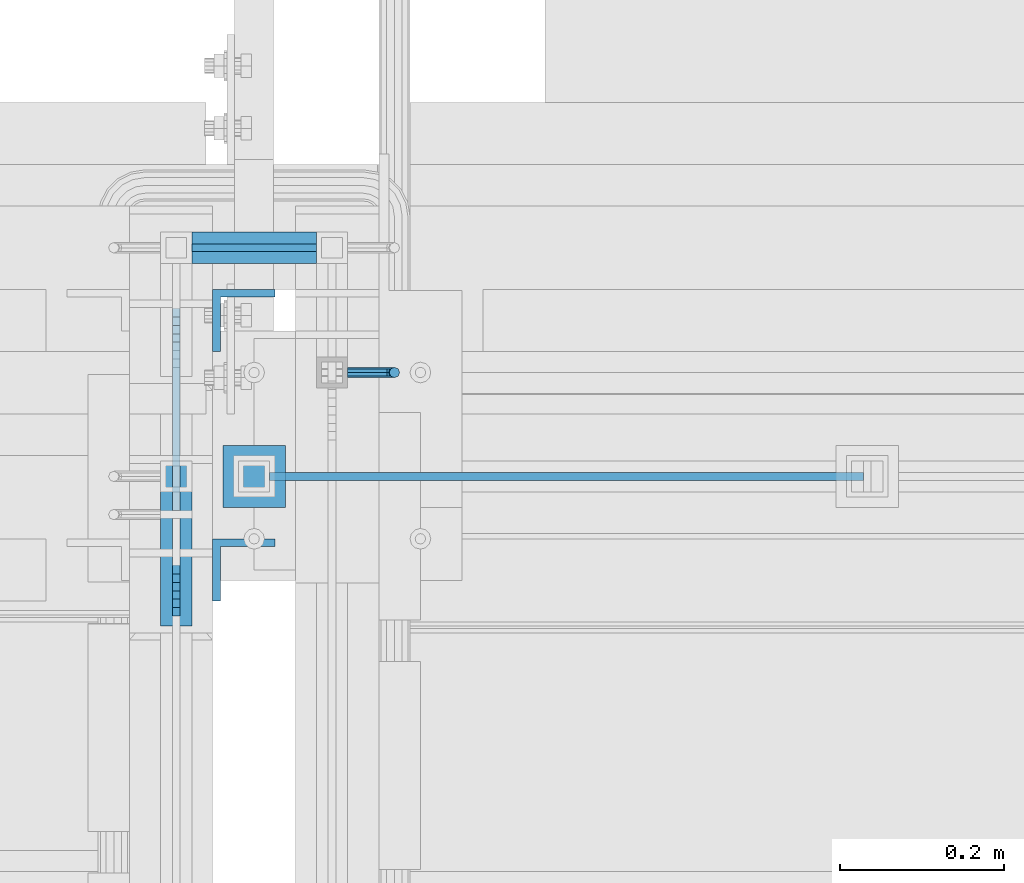
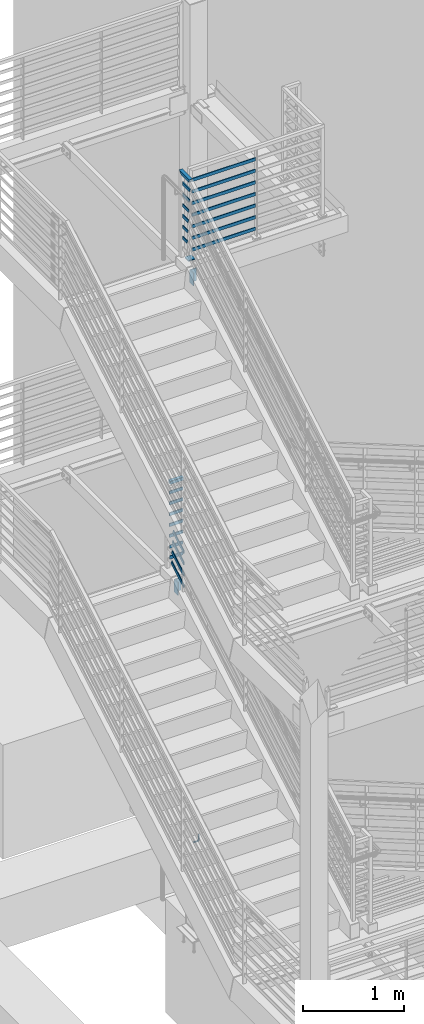
# One storey, part 864 of 1179: 26 beams, 4 members, 7 elements without a shape of their own.
"""IFC2X3 building model written with IfcOpenShell, lengths in millimetres."""

from ifc_helpers import new_model, si_unit, frame, origin_with_axes, place, context, subcontext, project, spatial, faceted_brep, material, type_object, element, aggregate, save


model = new_model("IFC2X3")

# Units and contexts
model_context = context("Model", 3, precision=1e-05, world=origin_with_axes())
body_context = subcontext(model_context, "Body", "Model", "MODEL_VIEW")
ifc_project = project(units=[si_unit("LENGTHUNIT", "METRE", prefix="MILLI"), si_unit("AREAUNIT", "SQUARE_METRE"), si_unit("VOLUMEUNIT", "CUBIC_METRE"), si_unit("MASSUNIT", "GRAM", prefix="KILO"), si_unit("TIMEUNIT", "SECOND"), si_unit("PLANEANGLEUNIT", "RADIAN"), si_unit("SOLIDANGLEUNIT", "STERADIAN"), si_unit("THERMODYNAMICTEMPERATUREUNIT", "DEGREE_CELSIUS"), si_unit("LUMINOUSINTENSITYUNIT", "LUMEN")], contexts=[model_context])

# Site, building, storey
site_placement = place(None, origin_with_axes())
site = spatial("IfcSite", under=ifc_project, at=site_placement, CompositionType="ELEMENT")
building_placement = place(site_placement, origin_with_axes())
building = spatial("IfcBuilding", under=site, at=building_placement, Name="Undefined", CompositionType="ELEMENT")
storey_placement = place(building_placement, origin_with_axes())
storey = spatial("IfcBuildingStorey", under=building, at=storey_placement, Name="Undefined", CompositionType="ELEMENT", Elevation=0.0)

# Assembly, beam
assembly_1_placement = place(storey_placement, origin_with_axes())
assembly_1 = element("IfcElementAssembly", 1, at=assembly_1_placement, inside=storey, Name="GUARDRAIL", AssemblyPlace="NOTDEFINED", PredefinedType="RIGID_FRAME")
ifc_material_1 = material(Name="STEEL/A36")
beam_type_1 = type_object("IfcBeamType", PredefinedType="NOTDEFINED")
beam_1_placement = place(assembly_1_placement, frame((-1638.3000007445, 35242.5000005577, 992.665205369077), z_axis=(0.0, 0.0, 1.0), x_axis=(1.0, 0.0, 0.0)))
beam_1 = element("IfcBeam", 2, at=beam_1_placement, type_object=beam_type_1, material=ifc_material_1, Name="BRACKET", context=body_context, shape_type="Brep", body=[
    faceted_brep([(0.0, -4.49012806053361, 4.49012806053452), (0.0, 0.0, 6.34999999999991), (0.0, 4.49012806053361, 4.49012806053452), (0.0, 6.34999999999854, 0.0), (0.0, 4.49012806053361, -4.49012806053452), (0.0, 0.0, -6.34999999999991), (0.0, -4.49012806053361, -4.49012806053452), (0.0, -6.34999999999854, 0.0), (44.4500031699827, 0.0, -6.34999999999991), (44.4500031699827, -4.49012806053361, -4.49012806053452), (44.4500031699827, -6.34999999999854, 2.19733919948339e-09), (44.4500031699827, -4.49012806053361, 4.49012806053452), (44.4500031699827, 0.0, 6.34999999999991), (44.4500031699827, 4.49012806053361, 4.49012806053452), (44.4500031699827, 6.34999999999854, 0.0), (44.4500031699827, 4.49012806053361, -4.49012806053452), (53.0450671075391, 4.4901280570557, -2.18708762112465), (53.97500307462, -4.32919478043914e-09, -3.79778396764459), (53.0450671022344, -4.49012806401151, -2.1870876194389), (50.8000030708674, -6.35000000142099, 1.70147734757802), (48.5549390416977, -4.4901280599006, 5.59004231389645), (47.6250030746168, 1.48793333210051e-09, 7.20073866041594), (48.5549390470023, 4.49012806117025, 5.5900423122107), (50.8000030783693, 6.34999999857973, 1.70147734519378), (55.4485256393576, 6.34999999469437, 6.34999990618098), (59.337090604122, 4.49012805180246, 4.10493587545716), (51.5599606707875, 4.49012805866005, 8.59506393599531), (49.9492643188311, -4.54747350886464e-10, 9.52499990463002), (51.5599606615996, -4.4901280624108, 8.59506393379797), (55.4485256263639, -6.35000000530636, 6.34999990307369), (59.337090594938, -4.49012806926839, 4.10493587326664), (60.9477869468905, -1.0153598850593e-08, 3.17499990462466), (61.6401310450869, 4.49012804462109, 12.6999998130159), (63.5000029792477, -1.81098585017025e-08, 12.6999998092651), (57.1500029867496, 6.3499999893902, 12.6999998145698), (52.6598749240178, 4.49012805522943, 12.6999998130159), (50.8000029792477, -3.10683390125632e-09, 12.6999998092651), (52.6598749134085, -4.49012806583778, 12.6999998055144), (57.1500029739432, -6.35000001061053, 12.6999998039605), (61.6401310344776, -4.49012807644976, 12.6999998055144), (63.5000029792478, -6.94672053214163e-08, 76.1999999999989), (61.6401294941604, -4.49012902507093, 78.7998225171882), (57.150001417061, -6.35000092034534, 79.8767042410154), (52.6598733730912, -4.49012891187158, 78.7998224516436), (50.8000029792478, -5.78438630327582e-08, 76.1999999999989), (52.6598734875952, 4.4901272704119, 73.6001773671805), (57.1500015724957, 6.34999916438028, 72.5232956441077), (61.6401296086642, 4.49012715460412, 73.6001774342335)], [[[0, 1, 2, 3, 4, 5, 6, 7]], [[6, 5, 8, 9]], [[7, 6, 9, 10]], [[0, 7, 10, 11]], [[1, 0, 11, 12]], [[2, 1, 12, 13]], [[3, 2, 13, 14]], [[4, 3, 14, 15]], [[5, 4, 15, 8]], [[8, 15, 16, 17]], [[9, 8, 17, 18]], [[10, 9, 18, 19]], [[11, 10, 19, 20]], [[12, 11, 20, 21]], [[13, 12, 21, 22]], [[14, 13, 22, 23]], [[15, 14, 23, 16]], [[23, 24, 25, 16]], [[22, 26, 24, 23]], [[21, 27, 26, 22]], [[20, 28, 27, 21]], [[19, 29, 28, 20]], [[18, 30, 29, 19]], [[17, 31, 30, 18]], [[16, 25, 31, 17]], [[25, 32, 33, 31]], [[24, 34, 32, 25]], [[26, 35, 34, 24]], [[27, 36, 35, 26]], [[28, 37, 36, 27]], [[29, 38, 37, 28]], [[30, 39, 38, 29]], [[31, 33, 39, 30]], [[39, 33, 40, 41]], [[38, 39, 41, 42]], [[37, 38, 42, 43]], [[36, 37, 43, 44]], [[35, 36, 44, 45]], [[34, 35, 45, 46]], [[32, 34, 46, 47]], [[33, 32, 47, 40]], [[46, 45, 44, 43, 42, 41, 40, 47]]]),
])
aggregate(assembly_1, [beam_1])

# Assembly, beams
assembly_2_placement = place(storey_placement, origin_with_axes())
assembly_2 = element("IfcElementAssembly", 3, at=assembly_2_placement, inside=storey, Name="GUARDRAIL", AssemblyPlace="NOTDEFINED", PredefinedType="RIGID_FRAME")
beam_type_2 = type_object("IfcBeamType", PredefinedType="NOTDEFINED")
beam_2_placement = place(assembly_2_placement, frame((-1828.81829244754, 35394.8983081136, 4394.23598620215), z_axis=(0.0, 0.0, 1.0), x_axis=(0.999999999938439, 1.10960000217655e-05, 0.0)))
beam_2 = element("IfcBeam", 4, at=beam_2_placement, type_object=beam_type_2, material=ifc_material_1, Name="PLATE", context=body_context, shape_type="Brep", body=[
    faceted_brep([(0.0, 4.76250000000073, -19.05), (0.0, 4.76250000000073, 19.0499992370605), (152.399956117868, 4.76250000043365, 19.0500000000002), (152.399956117868, 4.76250000043365, -19.0500000000002), (0.0, -4.76250000000073, 19.0499992370605), (152.399956117868, -4.76249999959691, 19.0500000000002), (0.0, -4.76250000000073, -19.05), (152.399956117868, -4.76249999959691, -19.0500000000002)], [[[0, 1, 2, 3]], [[1, 4, 5, 2]], [[4, 6, 7, 5]], [[6, 0, 3, 7]], [[5, 7, 3, 2]], [[6, 4, 1, 0]]]),
])
beam_3_placement = place(assembly_2_placement, frame((-1828.79960226161, 35394.898308321, 4524.37497131281), z_axis=(0.0, 0.0, 1.0), x_axis=(0.999999999938439, 1.10960000217655e-05, 0.0)))
beam_3 = element("IfcBeam", 5, at=beam_3_placement, type_object=beam_type_2, material=ifc_material_1, Name="PLATE", context=body_context, shape_type="Brep", body=[
    faceted_brep([(0.0, 4.76250000000073, -19.05), (0.0, 4.76250000000073, 19.0499992370605), (152.399956117868, 4.76250000043365, 19.0500000000002), (152.399956117868, 4.76250000043365, -19.0500000000002), (0.0, -4.76250000000073, 19.0499992370605), (152.399956117868, -4.76249999959691, 19.0500000000002), (0.0, -4.76250000000073, -19.05), (152.399956117868, -4.76249999959691, -19.0500000000002)], [[[0, 1, 2, 3]], [[1, 4, 5, 2]], [[4, 6, 7, 5]], [[6, 0, 3, 7]], [[5, 7, 3, 2]], [[6, 4, 1, 0]]]),
])
beam_4_placement = place(assembly_2_placement, frame((-1828.79960226161, 35394.8983089721, 4654.54997114588), z_axis=(0.0, 0.0, 1.0), x_axis=(0.999999999938439, 1.10960000217655e-05, 0.0)))
beam_4 = element("IfcBeam", 6, at=beam_4_placement, type_object=beam_type_2, material=ifc_material_1, Name="PLATE", context=body_context, shape_type="Brep", body=[
    faceted_brep([(0.0, 4.76250000000073, -19.05), (0.0, 4.76250000000073, 19.0499992370605), (152.399956117868, 4.76250000043365, 19.0500000000002), (152.399956117868, 4.76250000043365, -19.0500000000002), (0.0, -4.76250000000073, 19.0499992370605), (152.399956117868, -4.76249999959691, 19.0500000000002), (0.0, -4.76250000000073, -19.05), (152.399956117868, -4.76249999959691, -19.0500000000002)], [[[0, 1, 2, 3]], [[1, 4, 5, 2]], [[4, 6, 7, 5]], [[6, 0, 3, 7]], [[5, 7, 3, 2]], [[6, 4, 1, 0]]]),
])
beam_5_placement = place(assembly_2_placement, frame((-1828.79960226161, 35394.8983089721, 4784.72497215902), z_axis=(0.0, 0.0, 1.0), x_axis=(0.999999999938439, 1.10960000217655e-05, 0.0)))
beam_5 = element("IfcBeam", 7, at=beam_5_placement, type_object=beam_type_2, material=ifc_material_1, Name="PLATE", context=body_context, shape_type="Brep", body=[
    faceted_brep([(0.0, 4.76250000000073, -19.05), (0.0, 4.76250000000073, 19.0499992370605), (152.399956117868, 4.76250000043365, 19.0500000000002), (152.399956117868, 4.76250000043365, -19.0500000000002), (0.0, -4.76250000000073, 19.0499992370605), (152.399956117868, -4.76249999959691, 19.0500000000002), (0.0, -4.76250000000073, -19.05), (152.399956117868, -4.76249999959691, -19.0500000000002)], [[[0, 1, 2, 3]], [[1, 4, 5, 2]], [[4, 6, 7, 5]], [[6, 0, 3, 7]], [[5, 7, 3, 2]], [[6, 4, 1, 0]]]),
])
beam_6_placement = place(assembly_2_placement, frame((-1828.79960226161, 35394.8983089721, 4914.89997215621), z_axis=(0.0, 0.0, 1.0), x_axis=(0.999999999938439, 1.10960000217655e-05, 0.0)))
beam_6 = element("IfcBeam", 8, at=beam_6_placement, type_object=beam_type_2, material=ifc_material_1, Name="PLATE", context=body_context, shape_type="Brep", body=[
    faceted_brep([(0.0, 4.76250000000073, -19.05), (0.0, 4.76250000000073, 19.0499992370605), (152.399956117868, 4.76250000043365, 19.0500000000002), (152.399956117868, 4.76250000043365, -19.0500000000002), (0.0, -4.76250000000073, 19.0499992370605), (152.399956117868, -4.76249999959691, 19.0500000000002), (0.0, -4.76250000000073, -19.05), (152.399956117868, -4.76249999959691, -19.0500000000002)], [[[0, 1, 2, 3]], [[1, 4, 5, 2]], [[4, 6, 7, 5]], [[6, 0, 3, 7]], [[5, 7, 3, 2]], [[6, 4, 1, 0]]]),
])
beam_7_placement = place(assembly_2_placement, frame((-1828.79960226161, 35394.8983089721, 5045.07497215967), z_axis=(0.0, 0.0, 1.0), x_axis=(0.999999999938439, 1.10960000217655e-05, 0.0)))
beam_7 = element("IfcBeam", 9, at=beam_7_placement, type_object=beam_type_2, material=ifc_material_1, Name="PLATE", context=body_context, shape_type="Brep", body=[
    faceted_brep([(0.0, 4.76250000000073, -19.05), (0.0, 4.76250000000073, 19.0499992370605), (152.399956117868, 4.76250000043365, 19.0500000000002), (152.399956117868, 4.76250000043365, -19.0500000000002), (0.0, -4.76250000000073, 19.0499992370605), (152.399956117868, -4.76249999959691, 19.0500000000002), (0.0, -4.76250000000073, -19.05), (152.399956117868, -4.76249999959691, -19.0500000000002)], [[[0, 1, 2, 3]], [[1, 4, 5, 2]], [[4, 6, 7, 5]], [[6, 0, 3, 7]], [[5, 7, 3, 2]], [[6, 4, 1, 0]]]),
])
beam_8_placement = place(assembly_2_placement, frame((-1828.79960226161, 35394.8983089721, 5175.24997216603), z_axis=(0.0, 0.0, 1.0), x_axis=(0.999999999938439, 1.10960000217655e-05, 0.0)))
beam_8 = element("IfcBeam", 10, at=beam_8_placement, type_object=beam_type_2, material=ifc_material_1, Name="PLATE", context=body_context, shape_type="Brep", body=[
    faceted_brep([(0.0, 4.76250000000073, -19.05), (0.0, 4.76250000000073, 19.0499992370605), (152.399956117868, 4.76250000043365, 19.0500000000002), (152.399956117868, 4.76250000043365, -19.0500000000002), (0.0, -4.76250000000073, 19.0499992370605), (152.399956117868, -4.76249999959691, 19.0500000000002), (0.0, -4.76250000000073, -19.05), (152.399956117868, -4.76249999959691, -19.0500000000002)], [[[0, 1, 2, 3]], [[1, 4, 5, 2]], [[4, 6, 7, 5]], [[6, 0, 3, 7]], [[5, 7, 3, 2]], [[6, 4, 1, 0]]]),
])

assembly_3_placement = place(storey_placement, origin_with_axes())
assembly_3 = element("IfcElementAssembly", 11, at=assembly_3_placement, inside=storey, Name="GUARDRAIL", AssemblyPlace="NOTDEFINED", PredefinedType="RIGID_FRAME")
beam_9_placement = place(assembly_3_placement, frame((-1752.60069628364, 35115.5, 8236.00291878738), z_axis=(7.31000000250787e-05, 0.0, 0.999999997328195), x_axis=(0.999999997328195, 0.0, -7.31000000250648e-05)))
beam_9 = element("IfcBeam", 12, at=beam_9_placement, type_object=beam_type_2, material=ifc_material_1, Name="PLATE", context=body_context, shape_type="Brep", body=[
    faceted_brep([(19.0520881245343, 4.76249999999709, -19.0499999999938), (19.0493030145258, 4.76249999999709, 19.0499999999938), (744.536803398841, 4.76249999999709, 19.0500000000065), (744.539588508849, 4.76249999999709, -19.0499999999811), (19.0493030145258, -4.76249999999709, 19.0499999999938), (744.536803398841, -4.76249999999709, 19.0500000000065), (19.0520881245343, -4.76249999999709, -19.0499999999938), (744.539588508849, -4.76249999999709, -19.0499999999811)], [[[0, 1, 2, 3]], [[1, 4, 5, 2]], [[4, 6, 7, 5]], [[6, 0, 3, 7]], [[5, 7, 3, 2]], [[6, 4, 1, 0]]]),
])
beam_10_placement = place(assembly_3_placement, frame((-1752.60069628364, 35115.5, 8375.70291878737), z_axis=(7.31000000250787e-05, 0.0, 0.999999997328195), x_axis=(0.999999997328195, 0.0, -7.31000000250648e-05)))
beam_10 = element("IfcBeam", 13, at=beam_10_placement, type_object=beam_type_2, material=ifc_material_1, Name="PLATE", context=body_context, shape_type="Brep", body=[
    faceted_brep([(19.0520881245343, 4.76249999999709, -19.0499999999938), (19.0493030145258, 4.76249999999709, 19.0499999999938), (744.536803398841, 4.76249999999709, 19.0500000000065), (744.539588508849, 4.76249999999709, -19.0499999999811), (19.0493030145258, -4.76249999999709, 19.0499999999938), (744.536803398841, -4.76249999999709, 19.0500000000065), (19.0520881245343, -4.76249999999709, -19.0499999999938), (744.539588508849, -4.76249999999709, -19.0499999999811)], [[[0, 1, 2, 3]], [[1, 4, 5, 2]], [[4, 6, 7, 5]], [[6, 0, 3, 7]], [[5, 7, 3, 2]], [[6, 4, 1, 0]]]),
])
beam_11_placement = place(assembly_3_placement, frame((-1752.60069628364, 35115.5, 8515.40291878737), z_axis=(7.31000000250787e-05, 0.0, 0.999999997328195), x_axis=(0.999999997328195, 0.0, -7.31000000250648e-05)))
beam_11 = element("IfcBeam", 14, at=beam_11_placement, type_object=beam_type_2, material=ifc_material_1, Name="PLATE", context=body_context, shape_type="Brep", body=[
    faceted_brep([(19.0520881245343, 4.76249999999709, -19.0499999999938), (19.0493030145258, 4.76249999999709, 19.0499999999938), (744.536803398841, 4.76249999999709, 19.0500000000065), (744.539588508849, 4.76249999999709, -19.0499999999811), (19.0493030145258, -4.76249999999709, 19.0499999999938), (744.536803398841, -4.76249999999709, 19.0500000000065), (19.0520881245343, -4.76249999999709, -19.0499999999938), (744.539588508849, -4.76249999999709, -19.0499999999811)], [[[0, 1, 2, 3]], [[1, 4, 5, 2]], [[4, 6, 7, 5]], [[6, 0, 3, 7]], [[5, 7, 3, 2]], [[6, 4, 1, 0]]]),
])
beam_12_placement = place(assembly_3_placement, frame((-1752.60069628364, 35115.5, 8655.10291878737), z_axis=(7.31000000250787e-05, 0.0, 0.999999997328195), x_axis=(0.999999997328195, 0.0, -7.31000000250648e-05)))
beam_12 = element("IfcBeam", 15, at=beam_12_placement, type_object=beam_type_2, material=ifc_material_1, Name="PLATE", context=body_context, shape_type="Brep", body=[
    faceted_brep([(19.0520881245343, 4.76249999999709, -19.0499999999938), (19.0493030145258, 4.76249999999709, 19.0499999999938), (744.536803398841, 4.76249999999709, 19.0500000000065), (744.539588508849, 4.76249999999709, -19.0499999999811), (19.0493030145258, -4.76249999999709, 19.0499999999938), (744.536803398841, -4.76249999999709, 19.0500000000065), (19.0520881245343, -4.76249999999709, -19.0499999999938), (744.539588508849, -4.76249999999709, -19.0499999999811)], [[[0, 1, 2, 3]], [[1, 4, 5, 2]], [[4, 6, 7, 5]], [[6, 0, 3, 7]], [[5, 7, 3, 2]], [[6, 4, 1, 0]]]),
])
beam_13_placement = place(assembly_3_placement, frame((-1752.60069628364, 35115.5, 8794.80291878737), z_axis=(7.31000000250787e-05, 0.0, 0.999999997328195), x_axis=(0.999999997328195, 0.0, -7.31000000250648e-05)))
beam_13 = element("IfcBeam", 16, at=beam_13_placement, type_object=beam_type_2, material=ifc_material_1, Name="PLATE", context=body_context, shape_type="Brep", body=[
    faceted_brep([(19.0520881245343, 4.76249999999709, -19.0499999999938), (19.0493030145258, 4.76249999999709, 19.0499999999938), (744.536803398841, 4.76249999999709, 19.0500000000065), (744.539588508849, 4.76249999999709, -19.0499999999811), (19.0493030145258, -4.76249999999709, 19.0499999999938), (744.536803398841, -4.76249999999709, 19.0500000000065), (19.0520881245343, -4.76249999999709, -19.0499999999938), (744.539588508849, -4.76249999999709, -19.0499999999811)], [[[0, 1, 2, 3]], [[1, 4, 5, 2]], [[4, 6, 7, 5]], [[6, 0, 3, 7]], [[5, 7, 3, 2]], [[6, 4, 1, 0]]]),
])
beam_14_placement = place(assembly_3_placement, frame((-1752.60069628364, 35115.5, 8934.50291878736), z_axis=(7.31000000250787e-05, 0.0, 0.999999997328195), x_axis=(0.999999997328195, 0.0, -7.31000000250648e-05)))
beam_14 = element("IfcBeam", 17, at=beam_14_placement, type_object=beam_type_2, material=ifc_material_1, Name="PLATE", context=body_context, shape_type="Brep", body=[
    faceted_brep([(19.0520881245343, 4.76249999999709, -19.0499999999938), (19.0493030145258, 4.76249999999709, 19.0499999999938), (744.536803398841, 4.76249999999709, 19.0500000000065), (744.539588508849, 4.76249999999709, -19.0499999999811), (19.0493030145258, -4.76249999999709, 19.0499999999938), (744.536803398841, -4.76249999999709, 19.0500000000065), (19.0520881245343, -4.76249999999709, -19.0499999999938), (744.539588508849, -4.76249999999709, -19.0499999999811)], [[[0, 1, 2, 3]], [[1, 4, 5, 2]], [[4, 6, 7, 5]], [[6, 0, 3, 7]], [[5, 7, 3, 2]], [[6, 4, 1, 0]]]),
])
beam_15_placement = place(assembly_3_placement, frame((-1752.60069628364, 35115.5, 9074.20291878736), z_axis=(7.31000000250787e-05, 0.0, 0.999999997328195), x_axis=(0.999999997328195, 0.0, -7.31000000250648e-05)))
beam_15 = element("IfcBeam", 18, at=beam_15_placement, type_object=beam_type_2, material=ifc_material_1, Name="PLATE", context=body_context, shape_type="Brep", body=[
    faceted_brep([(19.0520881245343, 4.76249999999709, -19.0499999999938), (19.0493030145258, 4.76249999999709, 19.0499999999938), (744.536803398841, 4.76249999999709, 19.0500000000065), (744.539588508849, 4.76249999999709, -19.0499999999811), (19.0493030145258, -4.76249999999709, 19.0499999999938), (744.536803398841, -4.76249999999709, 19.0500000000065), (19.0520881245343, -4.76249999999709, -19.0499999999938), (744.539588508849, -4.76249999999709, -19.0499999999811)], [[[0, 1, 2, 3]], [[1, 4, 5, 2]], [[4, 6, 7, 5]], [[6, 0, 3, 7]], [[5, 7, 3, 2]], [[6, 4, 1, 0]]]),
])
aggregate(assembly_3, [beam_9, beam_10, beam_11, beam_12, beam_13, beam_14, beam_15])

assembly_4_placement = place(storey_placement, origin_with_axes())
assembly_4 = element("IfcElementAssembly", 19, at=assembly_4_placement, inside=storey, Name="GUARDRAIL", AssemblyPlace="NOTDEFINED", PredefinedType="RIGID_FRAME")
beam_16_placement = place(assembly_4_placement, frame((-1847.85000153055, 35090.0612093675, 8435.9975486085), z_axis=(0.0, 0.0, 1.0), x_axis=(0.0, -1.0, 0.0)))
beam_16 = element("IfcBeam", 20, at=beam_16_placement, type_object=beam_type_2, material=ifc_material_1, Name="PLATE", context=body_context, shape_type="Brep", body=[
    faceted_brep([(-6.38879139741039, 4.76250000000005, -19.0499999999993), (-6.38879139741039, 4.76250000000005, 19.0499999999993), (93.6723388623359, 4.76250000000005, 19.0499999999993), (83.3720365410554, 4.76250000000005, -19.0499999999993), (-6.38879139741039, -4.76250000000005, 19.0499999999993), (93.6723388623359, -4.76250000000005, 19.0499999999993), (-6.38879139741039, -4.76250000000005, -19.0499999999993), (83.3720365410554, -4.76250000000005, -19.0499999999993)], [[[0, 1, 2, 3]], [[1, 4, 5, 2]], [[4, 6, 7, 5]], [[6, 0, 3, 7]], [[5, 7, 3, 2]], [[6, 4, 1, 0]]]),
])
beam_17_placement = place(assembly_4_placement, frame((-1847.85000153055, 35090.0612093675, 8566.1725486085), z_axis=(0.0, 0.0, 1.0), x_axis=(0.0, -1.0, 0.0)))
beam_17 = element("IfcBeam", 21, at=beam_17_placement, type_object=beam_type_2, material=ifc_material_1, Name="PLATE", context=body_context, shape_type="Brep", body=[
    faceted_brep([(-6.38879139741039, 4.76250000000005, -19.0499999999993), (-6.38879139741039, 4.76250000000005, 19.0499999999993), (103.972641155066, 4.76250000000005, 19.0499999999993), (93.6723388337778, 4.76250000000005, -19.0499999999993), (-6.38879139741039, -4.76250000000005, 19.0499999999993), (103.972641155066, -4.76250000000005, 19.0499999999993), (-6.38879139741039, -4.76250000000005, -19.0499999999993), (93.6723388337778, -4.76250000000005, -19.0499999999993)], [[[0, 1, 2, 3]], [[1, 4, 5, 2]], [[4, 6, 7, 5]], [[6, 0, 3, 7]], [[5, 7, 3, 2]], [[6, 4, 1, 0]]]),
])
beam_18_placement = place(assembly_4_placement, frame((-1847.85000153055, 35090.0612093675, 8696.3475486085), z_axis=(0.0, 0.0, 1.0), x_axis=(0.0, -1.0, 0.0)))
beam_18 = element("IfcBeam", 22, at=beam_18_placement, type_object=beam_type_2, material=ifc_material_1, Name="PLATE", context=body_context, shape_type="Brep", body=[
    faceted_brep([(-6.38879139741039, 4.76250000000005, -19.0499999999993), (-6.38879139741039, 4.76250000000005, 19.0499999999993), (114.254664494685, 4.76250000000005, 19.0499999999993), (103.95450769709, 4.76250000000005, -19.0499999999993), (-6.38879139741039, -4.76250000000005, 19.0499999999993), (114.254664494685, -4.76250000000005, 19.0499999999993), (-6.38879139741039, -4.76250000000005, -19.0499999999993), (103.95450769709, -4.76250000000005, -19.0499999999993)], [[[0, 1, 2, 3]], [[1, 4, 5, 2]], [[4, 6, 7, 5]], [[6, 0, 3, 7]], [[5, 7, 3, 2]], [[6, 4, 1, 0]]]),
])
beam_19_placement = place(assembly_4_placement, frame((-1847.85000153055, 35090.0612093675, 8826.5225486085), z_axis=(0.0, 0.0, 1.0), x_axis=(0.0, -1.0, 0.0)))
beam_19 = element("IfcBeam", 23, at=beam_19_placement, type_object=beam_type_2, material=ifc_material_1, Name="PLATE", context=body_context, shape_type="Brep", body=[
    faceted_brep([(-6.38879139741039, 4.76250000000005, -19.0499999999993), (-6.38879139741039, 4.76250000000005, 19.0499999999993), (124.555136014736, 4.76250000000005, 19.0499999999993), (114.254979217134, 4.76250000000005, -19.0499999999993), (-6.38879139741039, -4.76250000000005, 19.0499999999993), (124.555136014736, -4.76250000000005, 19.0499999999993), (-6.38879139741039, -4.76250000000005, -19.0499999999993), (114.254979217134, -4.76250000000005, -19.0499999999993)], [[[0, 1, 2, 3]], [[1, 4, 5, 2]], [[4, 6, 7, 5]], [[6, 0, 3, 7]], [[5, 7, 3, 2]], [[6, 4, 1, 0]]]),
])
beam_20_placement = place(assembly_4_placement, frame((-1847.85000153055, 35090.0612093674, 8956.69754860849), z_axis=(0.0, 0.0, 1.0), x_axis=(0.0, -1.0, 0.0)))
beam_20 = element("IfcBeam", 24, at=beam_20_placement, type_object=beam_type_2, material=ifc_material_1, Name="PLATE", context=body_context, shape_type="Brep", body=[
    faceted_brep([(-6.38879139741039, 4.76250000000005, -19.0499999999993), (-6.38879139741039, 4.76250000000005, 19.0499999999993), (134.855607507663, 4.76250000000005, 19.0499999999993), (124.555450710068, 4.76250000000005, -19.0499999999993), (-6.38879139741039, -4.76250000000005, 19.0499999999993), (134.855607507663, -4.76250000000005, 19.0499999999993), (-6.38879139741039, -4.76250000000005, -19.0499999999993), (124.555450710068, -4.76250000000005, -19.0499999999993)], [[[0, 1, 2, 3]], [[1, 4, 5, 2]], [[4, 6, 7, 5]], [[6, 0, 3, 7]], [[5, 7, 3, 2]], [[6, 4, 1, 0]]]),
])
beam_21_placement = place(assembly_4_placement, frame((-1847.85000153055, 35090.0612093674, 9086.87254860849), z_axis=(0.0, 0.0, 1.0), x_axis=(0.0, -1.0, 0.0)))
beam_21 = element("IfcBeam", 25, at=beam_21_placement, type_object=beam_type_2, material=ifc_material_1, Name="PLATE", context=body_context, shape_type="Brep", body=[
    faceted_brep([(-6.38879139741039, 4.76250000000005, -19.0499999999993), (-6.38879139741039, 4.76250000000005, 19.0499999999993), (145.173850294232, 4.76250000000005, 19.0499999999993), (134.873547972951, 4.76250000000005, -19.0499999999993), (-6.38879139741039, -4.76250000000005, 19.0499999999993), (145.173850294232, -4.76250000000005, 19.0499999999993), (-6.38879139741039, -4.76250000000005, -19.0499999999993), (134.873547972951, -4.76250000000005, -19.0499999999993)], [[[0, 1, 2, 3]], [[1, 4, 5, 2]], [[4, 6, 7, 5]], [[6, 0, 3, 7]], [[5, 7, 3, 2]], [[6, 4, 1, 0]]]),
])

# Assembly, beam
assembly_5_placement = place(storey_placement, origin_with_axes())
assembly_5 = element("IfcElementAssembly", 26, at=assembly_5_placement, inside=storey, Name="ANGLE", AssemblyPlace="NOTDEFINED", PredefinedType="RIGID_FRAME")
beam_type_3 = type_object("IfcBeamType", Name="L3X3X3/8", PredefinedType="NOTDEFINED")
beam_22_placement = place(assembly_5_placement, frame((-1765.30000000477, 35001.1999998531, 8067.67499945061), z_axis=(1.0, 0.0, 0.0), x_axis=(0.0, 0.0, -1.0)))
beam_22 = element("IfcBeam", 27, at=beam_22_placement, type_object=beam_type_3, material=ifc_material_1, Name="ANGLE", ObjectType="L3X3X3/8", context=body_context, shape_type="Brep", body=[
    faceted_brep([(0.0, 38.0999999999985, -38.0999999999999), (0.0, 38.0999999999985, 38.0999999999999), (152.400000000001, 38.0999999999985, 38.0999999999999), (152.400000000001, 38.0999999999985, -38.0999999999999), (0.0, 28.5750000000007, 38.0999999999999), (152.400000000001, 28.5750000000007, 38.0999999999999), (0.0, 28.5750000000007, -28.575), (152.400000000001, 28.5750000000007, -28.575), (0.0, -38.0999999999985, -28.575), (152.400000000001, -38.0999999999985, -28.575), (0.0, -38.0999999999985, -38.0999999999999), (152.400000000001, -38.0999999999985, -38.0999999999999)], [[[0, 1, 2, 3]], [[1, 4, 5, 2]], [[4, 6, 7, 5]], [[6, 8, 9, 7]], [[8, 10, 11, 9]], [[10, 0, 3, 11]], [[5, 7, 9, 11, 3, 2]], [[10, 8, 6, 4, 1, 0]]]),
])
aggregate(assembly_5, [beam_22])

assembly_6_placement = place(storey_placement, origin_with_axes())
assembly_6 = element("IfcElementAssembly", 28, at=assembly_6_placement, inside=storey, Name="ANGLE", AssemblyPlace="NOTDEFINED", PredefinedType="RIGID_FRAME")
beam_23_placement = place(assembly_6_placement, frame((-1765.30000000477, 35306.0000000028, 4156.07499945083), z_axis=(1.0, 0.0, 0.0), x_axis=(0.0, 0.0, -1.0)))
beam_23 = element("IfcBeam", 29, at=beam_23_placement, type_object=beam_type_3, material=ifc_material_1, Name="ANGLE", ObjectType="L3X3X3/8", context=body_context, shape_type="Brep", body=[
    faceted_brep([(0.0, 38.0999999999985, -38.0999999999999), (0.0, 38.0999999999985, 38.0999999999999), (152.400000000001, 38.0999999999985, 38.0999999999999), (152.400000000001, 38.0999999999985, -38.0999999999999), (0.0, 28.5750000000007, 38.0999999999999), (152.400000000001, 28.5750000000007, 38.0999999999999), (0.0, 28.5750000000007, -28.575), (152.400000000001, 28.5750000000007, -28.575), (0.0, -38.0999999999985, -28.575), (152.400000000001, -38.0999999999985, -28.575), (0.0, -38.0999999999985, -38.0999999999999), (152.400000000001, -38.0999999999985, -38.0999999999999)], [[[0, 1, 2, 3]], [[1, 4, 5, 2]], [[4, 6, 7, 5]], [[6, 8, 9, 7]], [[8, 10, 11, 9]], [[10, 0, 3, 11]], [[5, 7, 9, 11, 3, 2]], [[10, 8, 6, 4, 1, 0]]]),
])
aggregate(assembly_6, [beam_23])

# Beam
ifc_material_2 = material()
beam_type_4 = type_object("IfcBeamType", Name="HSS1-1/2X1-1/2X1/4", PredefinedType="NOTDEFINED")
beam_24_placement = place(assembly_2_placement, frame((-1828.79960226161, 35394.8983089721, 5302.24999923244), z_axis=(0.0, 0.0, 1.0), x_axis=(0.999999999938439, 1.10960000217655e-05, 0.0)))
beam_24 = element("IfcBeam", 30, at=beam_24_placement, type_object=beam_type_4, material=ifc_material_2, Name="POST", ObjectType="HSS1-1/2X1-1/2X1/4", context=body_context, shape_type="Brep", body=[
    faceted_brep([(2.27373675443232e-13, 12.6999993300487, -12.6999993299996), (-6.82121026329696e-13, -12.6999993300415, -12.6999993299996), (152.399815200261, -12.6999993296267, -12.6999993299996), (152.399815200262, 12.6999993304562, -12.6999993299996), (-6.82121026329696e-13, -12.6999993300415, 12.6999993299996), (152.399815200261, -12.6999993296267, 12.6999993299996), (2.27373675443232e-13, 12.6999993300487, 12.6999993299996), (152.399815200262, 12.6999993304562, 12.6999993299996), (0.0, 19.0499992350015, -19.0499992349996), (0.0, 19.0499992350015, 19.0499992349996), (152.399815200263, 19.0499992354817, 19.0499992349996), (152.399815200263, 19.0499992354817, -19.0499992349996), (0.0, -19.0499992350015, 19.0499992349996), (152.399815200261, -19.0499992346522, 19.0499992349996), (0.0, -19.0499992350015, -19.0499992349996), (152.399815200261, -19.0499992346522, -19.0499992349996)], [[[0, 1, 2, 3]], [[1, 4, 5, 2]], [[4, 6, 7, 5]], [[6, 0, 3, 7]], [[8, 9, 10, 11]], [[9, 12, 13, 10]], [[12, 14, 15, 13]], [[14, 8, 11, 15]], [[13, 15, 11, 10], [5, 7, 3, 2]], [[14, 12, 9, 8], [6, 4, 1, 0]]]),
])

beam_25_placement = place(assembly_4_placement, frame((-1847.85000076555, 35090.0931538076, 9213.90291598889), z_axis=(0.0, -0.000359384000148566, 0.999999935421568), x_axis=(0.0, -0.999999935421568, -0.000359384000147012)))
beam_25 = element("IfcBeam", 31, at=beam_25_placement, type_object=beam_type_4, material=ifc_material_2, Name="GUARDRAIL", ObjectType="HSS1-1/2X1-1/2X1/4", context=body_context, shape_type="Brep", body=[
    faceted_brep([(-12.7022835116222, 12.6999993300001, -12.6999993300178), (-12.7022835116222, -12.6999993300001, -12.6999993300178), (148.961876344903, -12.6999993300001, -12.6999993298741), (148.961876344903, 12.6999993300001, -12.6999993298741), (-38.1114121606734, -12.6999993300001, 12.6999993299742), (155.838561124721, -12.6999993300001, 12.6999993301506), (-38.1114121606734, 12.6999993300001, 12.6999993299742), (155.838561124721, 12.6999993300001, 12.6999993301506), (-6.35000110926921, 19.0499992350001, -19.0499992350178), (-44.4636945630264, 19.0499992350001, 19.0499992349705), (157.557732384652, 19.0499992350001, 19.0499992351561), (147.24270508498, 19.0499992350001, -19.0499992348796), (-44.4636945630264, -19.0499992350001, 19.0499992349705), (157.557732384652, -19.0499992350001, 19.0499992351561), (-6.35000110926921, -19.0499992350001, -19.0499992350178), (147.24270508498, -19.0499992350001, -19.0499992348796)], [[[0, 1, 2, 3]], [[1, 4, 5, 2]], [[4, 6, 7, 5]], [[6, 0, 3, 7]], [[8, 9, 10, 11]], [[9, 12, 13, 10]], [[12, 14, 15, 13]], [[14, 8, 11, 15]], [[13, 15, 11, 10], [5, 7, 3, 2]], [[14, 12, 9, 8], [6, 4, 1, 0]]]),
])

aggregate(assembly_4, [beam_16, beam_17, beam_18, beam_19, beam_20, beam_21, beam_25])

# Assembly, beam
assembly_7_placement = place(storey_placement, origin_with_axes())
assembly_7 = element("IfcElementAssembly", 32, at=assembly_7_placement, inside=storey, Name="SLEEVE", AssemblyPlace="NOTDEFINED", PredefinedType="RIGID_FRAME")
beam_type_5 = type_object("IfcBeamType", PredefinedType="NOTDEFINED")
beam_26_placement = place(assembly_7_placement, frame((-1790.7, 35115.5, 8140.75477407027), z_axis=(0.0, 1.0, 0.0), x_axis=(1.0, 0.0, 0.0)))
beam_26 = element("IfcBeam", 33, at=beam_26_placement, type_object=beam_type_5, material=ifc_material_1, Name="PLATE", context=body_context, shape_type="Brep", body=[
    faceted_brep([(0.0, 6.35000000000036, -38.0999999999985), (0.0, 6.35000000000036, 38.0999999999985), (76.2, 6.35000000000036, 38.0999999999985), (76.2, 6.35000000000036, -38.0999999999985), (0.0, -6.35000000000036, 38.0999999999985), (76.2, -6.35000000000036, 38.0999999999985), (0.0, -6.35000000000036, -38.0999999999985), (76.2, -6.35000000000036, -38.0999999999985)], [[[0, 1, 2, 3]], [[1, 4, 5, 2]], [[4, 6, 7, 5]], [[6, 0, 3, 7]], [[5, 7, 3, 2]], [[6, 4, 1, 0]]]),
])
aggregate(assembly_7, [beam_26])

# Member
member_type = type_object("IfcMemberType", PredefinedType="NOTDEFINED")
member_1_placement = place(assembly_2_placement, frame((-1847.85000076555, 35328.1455886713, 4401.6066364028), z_axis=(0.0, -0.501065882891537, 0.865409140812671), x_axis=(0.0, -0.86540914081267, -0.501065882891538)))
member_1 = element("IfcMember", 34, at=member_1_placement, type_object=member_type, material=ifc_material_1, Name="PLATE", context=body_context, shape_type="Brep", body=[
    faceted_brep([(19.8262184614396, 4.76250000000005, -19.0500000000138), (9.59221147395874, 4.76250000000005, 19.0499999999756), (282.99267793445, 4.76250000000005, 19.0499999996009), (305.052313357544, 4.76250000000005, -19.0500000004067), (9.59221147395874, -4.76250000000005, 19.0499999999756), (282.99267793445, -4.76250000000005, 19.0499999996009), (19.8262184614396, -4.76250000000005, -19.0500000000138), (305.052313357544, -4.76250000000005, -19.0500000004067)], [[[0, 1, 2, 3]], [[1, 4, 5, 2]], [[4, 6, 7, 5]], [[6, 0, 3, 7]], [[5, 7, 3, 2]], [[6, 4, 1, 0]]]),
])

member_2_placement = place(assembly_2_placement, frame((-1847.85000076555, 35317.1782723324, 4531.35705536935), z_axis=(0.0, -0.501065882891537, 0.865409140812671), x_axis=(0.0, -0.86540914081267, -0.501065882891538)))
member_2 = element("IfcMember", 35, at=member_2_placement, type_object=member_type, material=ifc_material_1, Name="PLATE", context=body_context, shape_type="Brep", body=[
    faceted_brep([(18.9788627584785, 4.76249999999982, -19.0500000000175), (8.74485577100859, 4.76249999999982, 19.049999999972), (270.31969376819, 4.76249999999982, 19.0499999996155), (292.379329191284, 4.76249999999982, -19.0500000003922), (8.74485577100859, -4.76250000000027, 19.049999999972), (270.31969376819, -4.76250000000027, 19.0499999996155), (18.9788627584785, -4.76250000000027, -19.0500000000175), (292.379329191284, -4.76250000000027, -19.0500000003922)], [[[0, 1, 2, 3]], [[1, 4, 5, 2]], [[4, 6, 7, 5]], [[6, 0, 3, 7]], [[5, 7, 3, 2]], [[6, 4, 1, 0]]]),
])

member_3_placement = place(assembly_2_placement, frame((-1847.85000076555, 35306.2109559658, 4661.10747432382), z_axis=(0.0, -0.501065882891537, 0.865409140812671), x_axis=(0.0, -0.86540914081267, -0.501065882891538)))
member_3 = element("IfcMember", 36, at=member_3_placement, type_object=member_type, material=ifc_material_1, Name="PLATE", context=body_context, shape_type="Brep", body=[
    faceted_brep([(18.1315070314158, 4.76250000000005, -19.050000000012), (7.89750004393863, 4.76250000000005, 19.0499999999811), (257.646709569875, 4.76250000000005, 19.0499999996373), (279.70634499297, 4.76250000000005, -19.0500000003703), (7.89750004393863, -4.76250000000005, 19.0499999999811), (257.646709569875, -4.76250000000005, 19.0499999996373), (18.1315070314158, -4.76250000000005, -19.050000000012), (279.70634499297, -4.76250000000005, -19.0500000003703)], [[[0, 1, 2, 3]], [[1, 4, 5, 2]], [[4, 6, 7, 5]], [[6, 0, 3, 7]], [[5, 7, 3, 2]], [[6, 4, 1, 0]]]),
])

member_4_placement = place(assembly_2_placement, frame((-1847.85000076555, 35295.2436396223, 4790.85789328842), z_axis=(0.0, -0.501065882891537, 0.865409140812671), x_axis=(0.0, -0.86540914081267, -0.501065882891538)))
member_4 = element("IfcMember", 37, at=member_4_placement, type_object=member_type, material=ifc_material_1, Name="PLATE", context=body_context, shape_type="Brep", body=[
    faceted_brep([(17.2841513245876, 4.76250000000005, -19.050000000012), (7.0501443371104, 4.76250000000005, 19.0499999999774), (244.97372539834, 4.76250000000005, 19.0499999996537), (267.033360821439, 4.76250000000005, -19.0500000003558), (7.0501443371104, -4.76250000000005, 19.0499999999774), (244.97372539834, -4.76250000000005, 19.0499999996537), (17.2841513245876, -4.76250000000005, -19.050000000012), (267.033360821439, -4.76250000000005, -19.0500000003558)], [[[0, 1, 2, 3]], [[1, 4, 5, 2]], [[4, 6, 7, 5]], [[6, 0, 3, 7]], [[5, 7, 3, 2]], [[6, 4, 1, 0]]]),
])

aggregate(assembly_2, [beam_2, beam_3, beam_4, beam_5, beam_6, beam_7, beam_8, beam_24, member_1, member_2, member_3, member_4])

save(model, "model.ifc")
